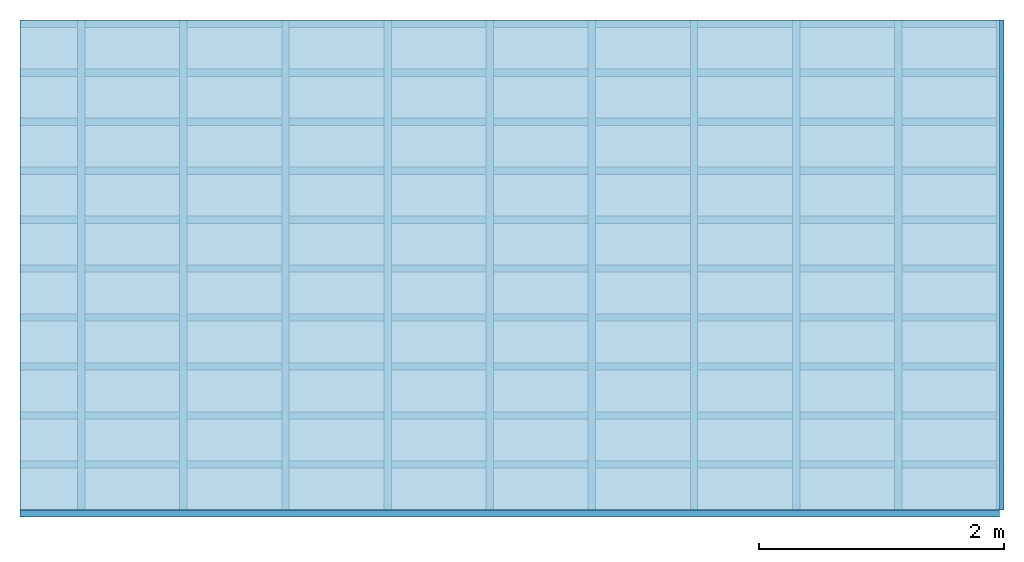
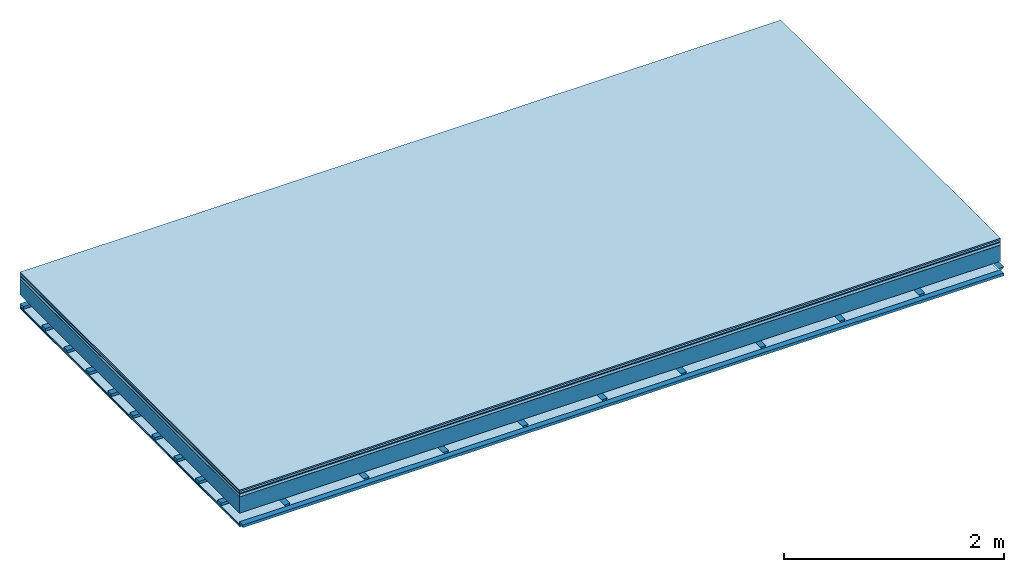
# One storey: 8 plates, 3 members, 1 element without a shape of its own.
"""IFC4 building model written with IfcOpenShell, lengths in metres."""

from ifc_helpers import new_model, si_unit, derived_unit, direction, frame, frame_2d, origin, origin_with_axes, place, context, project, spatial, polyline, rectangle, outline, extrude, material, layer, layer_set, type_object, element, aggregate, save


model = new_model("IFC4")

# Units and contexts
plan_context = context("Plan", 3, precision=1e-05, world=origin(), true_north=direction((0.0, 1.0)))
model_context = context("Model", 3, precision=1e-05, world=origin(), true_north=direction((0.0, 1.0)))
ifc_project = project(units=[si_unit("LENGTHUNIT", "METRE"), derived_unit("SOUNDPRESSUREUNIT", [(si_unit("PRESSUREUNIT", "PASCAL", prefix="MICRO"), 0)]), si_unit("ENERGYUNIT", "JOULE", prefix="MEGA"), si_unit("MASSUNIT", "GRAM", prefix="KILO"), derived_unit("THERMALTRANSMITTANCEUNIT", [(si_unit("POWERUNIT", "WATT"), 1), (si_unit("AREAUNIT", "SQUARE_METRE"), -1), (si_unit("THERMODYNAMICTEMPERATUREUNIT", "KELVIN"), -1)]), derived_unit("AREADENSITYUNIT", [(si_unit("MASSUNIT", "GRAM", prefix="KILO"), 1), (si_unit("AREAUNIT", "SQUARE_METRE"), -1)]), derived_unit("USERDEFINED", [(si_unit("ENERGYUNIT", "JOULE", prefix="MEGA"), 1), (si_unit("AREAUNIT", "SQUARE_METRE"), -1)])], contexts=[plan_context, model_context])

# Site, building, storey
site = spatial("IfcSite", under=ifc_project)
building_placement = place(None, origin())
building = spatial("IfcBuilding", under=site, at=building_placement)
storey_placement = place(building_placement, origin())
storey = spatial("IfcBuildingStorey", under=building, at=storey_placement)

# Slab, members, plates
ifc_material_1 = material(Category="11.013")
ifc_layer_1 = layer(ifc_material_1, 0.015, Name="Flooring")
ifc_material_2 = material(Category="03.007")
ifc_layer_2 = layer(ifc_material_2, 0.02, Name="On-material")
ifc_material_3 = material(Name="Wood fiber generic product", Category="10.009")
ifc_layer_3 = layer(ifc_material_3, 0.01, Name="Impact sound insulation")
ifc_material_4 = material(Name="with broken")
ifc_layer_4 = layer(ifc_material_4, 0.03, Name="on Supporting structure")
ifc_material_5 = material(Name="protection", Category="09.007")
ifc_layer_5 = layer(ifc_material_5, 0.0005, Name="Sub-floor")
ifc_material_6 = material(Name="no composite action")
ifc_layer_6 = layer(ifc_material_6, 0.0, Name="Bond")
ifc_layer_7 = layer(None, 0.18, Name="Supporting structure")
ifc_layer_8 = layer(ifc_material_6, 0.0, Name="Bond")
ifc_layer_9 = layer(None, 0.095, Name="Coupling")
ifc_layer_10 = layer(None, 0.03, Name="Battens / profiles")
ifc_material_7 = material(Name="Plasterboard type A", Category="03.008")
ifc_layer_11 = layer(ifc_material_7, 0.0125, Name="Ceiling covering 1st layer")
ifc_layer_12 = layer(ifc_material_7, 0.0125, Name="Ceiling covering layer 2")
ifc_material_8 = material(Category="04.001")
ifc_layer_13 = layer(ifc_material_8, 0.003, Name="Surface / treatment")
ifc_layer_set = layer_set([ifc_layer_1, ifc_layer_2, ifc_layer_3, ifc_layer_4, ifc_layer_5, ifc_layer_6, ifc_layer_7, ifc_layer_8, ifc_layer_9, ifc_layer_10, ifc_layer_11, ifc_layer_12, ifc_layer_13])
slab_type = type_object("IfcSlabType", Name="A2117", PredefinedType="NOTDEFINED", material=ifc_layer_set)
slab_placement = place(None, frame((0.0, 0.0, 0.0), z_axis=(0.0, 0.0, -1.0), x_axis=(1.0, 0.0, 0.0)))
slab = element("IfcSlab", 1, at=slab_placement, inside=storey, type_object=slab_type, material=ifc_layer_set, Name="Slab #1")
ifc_material_9 = material(Name="Solid timber panel")
member_1_placement = place(slab_placement, origin())
member_1 = element("IfcMember", 2, at=member_1_placement, material=ifc_material_9, Name="Supporting structure", context=plan_context, shape_type="SweptSolid", body=[
    extrude(rectangle(XDim=1.0, YDim=0.18, at=frame_2d((0.5, 0.09), x_axis=(1.0, 0.0))), frame((0.0, 4.0, 0.0755), z_axis=(0.0, -1.0, 0.0), x_axis=(1.0, 0.0, 0.0)), (0.0, 0.0, 1.0), 4.0),
    extrude(rectangle(XDim=1.0, YDim=0.18, at=frame_2d((0.5, 0.09), x_axis=(1.0, 0.0))), frame((1.0, 4.0, 0.0755), z_axis=(0.0, -1.0, 0.0), x_axis=(1.0, 0.0, 0.0)), (0.0, 0.0, 1.0), 4.0),
    extrude(rectangle(XDim=1.0, YDim=0.18, at=frame_2d((0.5, 0.09), x_axis=(1.0, 0.0))), frame((2.0, 4.0, 0.0755), z_axis=(0.0, -1.0, 0.0), x_axis=(1.0, 0.0, 0.0)), (0.0, 0.0, 1.0), 4.0),
    extrude(rectangle(XDim=1.0, YDim=0.18, at=frame_2d((0.5, 0.09), x_axis=(1.0, 0.0))), frame((3.0, 4.0, 0.0755), z_axis=(0.0, -1.0, 0.0), x_axis=(1.0, 0.0, 0.0)), (0.0, 0.0, 1.0), 4.0),
    extrude(rectangle(XDim=1.0, YDim=0.18, at=frame_2d((0.5, 0.09), x_axis=(1.0, 0.0))), frame((4.0, 4.0, 0.0755), z_axis=(0.0, -1.0, 0.0), x_axis=(1.0, 0.0, 0.0)), (0.0, 0.0, 1.0), 4.0),
    extrude(rectangle(XDim=1.0, YDim=0.18, at=frame_2d((0.5, 0.09), x_axis=(1.0, 0.0))), frame((5.0, 4.0, 0.0755), z_axis=(0.0, -1.0, 0.0), x_axis=(1.0, 0.0, 0.0)), (0.0, 0.0, 1.0), 4.0),
    extrude(rectangle(XDim=1.0, YDim=0.18, at=frame_2d((0.5, 0.09), x_axis=(1.0, 0.0))), frame((6.0, 4.0, 0.0755), z_axis=(0.0, -1.0, 0.0), x_axis=(1.0, 0.0, 0.0)), (0.0, 0.0, 1.0), 4.0),
    extrude(rectangle(XDim=1.0, YDim=0.18, at=frame_2d((0.5, 0.09), x_axis=(1.0, 0.0))), frame((7.0, 4.0, 0.0755), z_axis=(0.0, -1.0, 0.0), x_axis=(1.0, 0.0, 0.0)), (0.0, 0.0, 1.0), 4.0),
])
ifc_material_10 = material()
member_2_placement = place(slab_placement, origin())
member_2 = element("IfcMember", 3, at=member_2_placement, material=ifc_material_10, Name="Coupling", context=plan_context, shape_type="SweptSolid", body=[
    extrude(outline(polyline([(0.0, 0.0), (0.06, 0.0), (0.04, 0.02), (0.02, 0.02), (0.0, 0.0)])), frame((0.47, 4.0, 0.3305), z_axis=(0.0, -1.0, 0.0), x_axis=(1.0, 0.0, 0.0)), (0.0, 0.0, 1.0), 4.0),
    extrude(outline(polyline([(0.0, 0.0), (0.06, 0.0), (0.04, 0.02), (0.02, 0.02), (0.0, 0.0)])), frame((1.304, 4.0, 0.3305), z_axis=(0.0, -1.0, 0.0), x_axis=(1.0, 0.0, 0.0)), (0.0, 0.0, 1.0), 4.0),
    extrude(outline(polyline([(0.0, 0.0), (0.06, 0.0), (0.04, 0.02), (0.02, 0.02), (0.0, 0.0)])), frame((2.138, 4.0, 0.3305), z_axis=(0.0, -1.0, 0.0), x_axis=(1.0, 0.0, 0.0)), (0.0, 0.0, 1.0), 4.0),
    extrude(outline(polyline([(0.0, 0.0), (0.06, 0.0), (0.04, 0.02), (0.02, 0.02), (0.0, 0.0)])), frame((2.972, 4.0, 0.3305), z_axis=(0.0, -1.0, 0.0), x_axis=(1.0, 0.0, 0.0)), (0.0, 0.0, 1.0), 4.0),
    extrude(outline(polyline([(0.0, 0.0), (0.06, 0.0), (0.04, 0.02), (0.02, 0.02), (0.0, 0.0)])), frame((3.806, 4.0, 0.3305), z_axis=(0.0, -1.0, 0.0), x_axis=(1.0, 0.0, 0.0)), (0.0, 0.0, 1.0), 4.0),
    extrude(outline(polyline([(0.0, 0.0), (0.06, 0.0), (0.04, 0.02), (0.02, 0.02), (0.0, 0.0)])), frame((4.64, 4.0, 0.3305), z_axis=(0.0, -1.0, 0.0), x_axis=(1.0, 0.0, 0.0)), (0.0, 0.0, 1.0), 4.0),
    extrude(outline(polyline([(0.0, 0.0), (0.06, 0.0), (0.04, 0.02), (0.02, 0.02), (0.0, 0.0)])), frame((5.474, 4.0, 0.3305), z_axis=(0.0, -1.0, 0.0), x_axis=(1.0, 0.0, 0.0)), (0.0, 0.0, 1.0), 4.0),
    extrude(outline(polyline([(0.0, 0.0), (0.06, 0.0), (0.04, 0.02), (0.02, 0.02), (0.0, 0.0)])), frame((6.308, 4.0, 0.3305), z_axis=(0.0, -1.0, 0.0), x_axis=(1.0, 0.0, 0.0)), (0.0, 0.0, 1.0), 4.0),
    extrude(outline(polyline([(0.0, 0.0), (0.06, 0.0), (0.04, 0.02), (0.02, 0.02), (0.0, 0.0)])), frame((7.142, 4.0, 0.3305), z_axis=(0.0, -1.0, 0.0), x_axis=(1.0, 0.0, 0.0)), (0.0, 0.0, 1.0), 4.0),
    extrude(outline(polyline([(0.0, 0.0), (0.06, 0.0), (0.04, 0.02), (0.02, 0.02), (0.0, 0.0)])), frame((7.976, 4.0, 0.3305), z_axis=(0.0, -1.0, 0.0), x_axis=(1.0, 0.0, 0.0)), (0.0, 0.0, 1.0), 4.0),
])
member_3_placement = place(slab_placement, origin())
member_3 = element("IfcMember", 4, at=member_3_placement, material=ifc_material_10, Name="Battens / profiles", context=plan_context, shape_type="SweptSolid", body=[
    extrude(rectangle(XDim=0.06, YDim=0.03, at=frame_2d((0.03, 0.015), x_axis=(1.0, 0.0))), frame((0.0, 0.0, 0.3505), z_axis=(1.0, 0.0, 0.0), x_axis=(0.0, 1.0, 0.0)), (0.0, 0.0, 1.0), 8.0),
    extrude(rectangle(XDim=0.06, YDim=0.03, at=frame_2d((0.03, 0.015), x_axis=(1.0, 0.0))), frame((0.0, 0.4, 0.3505), z_axis=(1.0, 0.0, 0.0), x_axis=(0.0, 1.0, 0.0)), (0.0, 0.0, 1.0), 8.0),
    extrude(rectangle(XDim=0.06, YDim=0.03, at=frame_2d((0.03, 0.015), x_axis=(1.0, 0.0))), frame((0.0, 0.8, 0.3505), z_axis=(1.0, 0.0, 0.0), x_axis=(0.0, 1.0, 0.0)), (0.0, 0.0, 1.0), 8.0),
    extrude(rectangle(XDim=0.06, YDim=0.03, at=frame_2d((0.03, 0.015), x_axis=(1.0, 0.0))), frame((0.0, 1.2, 0.3505), z_axis=(1.0, 0.0, 0.0), x_axis=(0.0, 1.0, 0.0)), (0.0, 0.0, 1.0), 8.0),
    extrude(rectangle(XDim=0.06, YDim=0.03, at=frame_2d((0.03, 0.015), x_axis=(1.0, 0.0))), frame((0.0, 1.6, 0.3505), z_axis=(1.0, 0.0, 0.0), x_axis=(0.0, 1.0, 0.0)), (0.0, 0.0, 1.0), 8.0),
    extrude(rectangle(XDim=0.06, YDim=0.03, at=frame_2d((0.03, 0.015), x_axis=(1.0, 0.0))), frame((0.0, 2.0, 0.3505), z_axis=(1.0, 0.0, 0.0), x_axis=(0.0, 1.0, 0.0)), (0.0, 0.0, 1.0), 8.0),
    extrude(rectangle(XDim=0.06, YDim=0.03, at=frame_2d((0.03, 0.015), x_axis=(1.0, 0.0))), frame((0.0, 2.4, 0.3505), z_axis=(1.0, 0.0, 0.0), x_axis=(0.0, 1.0, 0.0)), (0.0, 0.0, 1.0), 8.0),
    extrude(rectangle(XDim=0.06, YDim=0.03, at=frame_2d((0.03, 0.015), x_axis=(1.0, 0.0))), frame((0.0, 2.8, 0.3505), z_axis=(1.0, 0.0, 0.0), x_axis=(0.0, 1.0, 0.0)), (0.0, 0.0, 1.0), 8.0),
    extrude(rectangle(XDim=0.06, YDim=0.03, at=frame_2d((0.03, 0.015), x_axis=(1.0, 0.0))), frame((0.0, 3.2, 0.3505), z_axis=(1.0, 0.0, 0.0), x_axis=(0.0, 1.0, 0.0)), (0.0, 0.0, 1.0), 8.0),
    extrude(rectangle(XDim=0.06, YDim=0.03, at=frame_2d((0.03, 0.015), x_axis=(1.0, 0.0))), frame((0.0, 3.6, 0.3505), z_axis=(1.0, 0.0, 0.0), x_axis=(0.0, 1.0, 0.0)), (0.0, 0.0, 1.0), 8.0),
    extrude(rectangle(XDim=0.06, YDim=0.03, at=frame_2d((0.03, 0.015), x_axis=(1.0, 0.0))), frame((0.0, 4.0, 0.3505), z_axis=(1.0, 0.0, 0.0), x_axis=(0.0, 1.0, 0.0)), (0.0, 0.0, 1.0), 8.0),
])
plate_1_placement = place(slab_placement, origin())
plate_1 = element("IfcPlate", 5, at=plate_1_placement, material=ifc_material_1, Name="Flooring", context=plan_context, shape_type="SweptSolid", body=[
    extrude(rectangle(XDim=8.0, YDim=4.0, at=frame_2d((4.0, 2.0), x_axis=(1.0, 0.0))), origin_with_axes(), (0.0, 0.0, 1.0), 0.015),
])
plate_2_placement = place(slab_placement, origin())
plate_2 = element("IfcPlate", 6, at=plate_2_placement, material=ifc_material_2, Name="On-material", context=plan_context, shape_type="SweptSolid", body=[
    extrude(rectangle(XDim=8.0, YDim=4.0, at=frame_2d((4.0, 2.0), x_axis=(1.0, 0.0))), frame((0.0, 0.0, 0.015), z_axis=(0.0, 0.0, 1.0), x_axis=(1.0, 0.0, 0.0)), (0.0, 0.0, 1.0), 0.02),
])
plate_3_placement = place(slab_placement, origin())
plate_3 = element("IfcPlate", 7, at=plate_3_placement, material=ifc_material_3, Name="Impact sound insulation", context=plan_context, shape_type="SweptSolid", body=[
    extrude(rectangle(XDim=8.0, YDim=4.0, at=frame_2d((4.0, 2.0), x_axis=(1.0, 0.0))), frame((0.0, 0.0, 0.035), z_axis=(0.0, 0.0, 1.0), x_axis=(1.0, 0.0, 0.0)), (0.0, 0.0, 1.0), 0.01),
])
plate_4_placement = place(slab_placement, origin())
plate_4 = element("IfcPlate", 8, at=plate_4_placement, material=ifc_material_4, Name="on Supporting structure", context=plan_context, shape_type="SweptSolid", body=[
    extrude(rectangle(XDim=8.0, YDim=4.0, at=frame_2d((4.0, 2.0), x_axis=(1.0, 0.0))), frame((0.0, 0.0, 0.045), z_axis=(0.0, 0.0, 1.0), x_axis=(1.0, 0.0, 0.0)), (0.0, 0.0, 1.0), 0.03),
])
plate_5_placement = place(slab_placement, origin())
plate_5 = element("IfcPlate", 9, at=plate_5_placement, material=ifc_material_5, Name="Sub-floor", context=plan_context, shape_type="SweptSolid", body=[
    extrude(rectangle(XDim=8.0, YDim=4.0, at=frame_2d((4.0, 2.0), x_axis=(1.0, 0.0))), frame((0.0, 0.0, 0.075), z_axis=(0.0, 0.0, 1.0), x_axis=(1.0, 0.0, 0.0)), (0.0, 0.0, 1.0), 0.0005),
])
plate_6_placement = place(slab_placement, origin())
plate_6 = element("IfcPlate", 10, at=plate_6_placement, material=ifc_material_7, Name="Ceiling covering 1st layer", context=plan_context, shape_type="SweptSolid", body=[
    extrude(rectangle(XDim=8.0, YDim=4.0, at=frame_2d((4.0, 2.0), x_axis=(1.0, 0.0))), frame((0.0, 0.0, 0.3805), z_axis=(0.0, 0.0, 1.0), x_axis=(1.0, 0.0, 0.0)), (0.0, 0.0, 1.0), 0.0125),
])
plate_7_placement = place(slab_placement, origin())
plate_7 = element("IfcPlate", 11, at=plate_7_placement, material=ifc_material_7, Name="Ceiling covering layer 2", context=plan_context, shape_type="SweptSolid", body=[
    extrude(rectangle(XDim=8.0, YDim=4.0, at=frame_2d((4.0, 2.0), x_axis=(1.0, 0.0))), frame((0.0, 0.0, 0.393), z_axis=(0.0, 0.0, 1.0), x_axis=(1.0, 0.0, 0.0)), (0.0, 0.0, 1.0), 0.0125),
])
plate_8_placement = place(slab_placement, origin())
plate_8 = element("IfcPlate", 12, at=plate_8_placement, material=ifc_material_8, Name="Surface / treatment", context=plan_context, shape_type="SweptSolid", body=[
    extrude(rectangle(XDim=8.0, YDim=4.0, at=frame_2d((4.0, 2.0), x_axis=(1.0, 0.0))), frame((0.0, 0.0, 0.4055), z_axis=(0.0, 0.0, 1.0), x_axis=(1.0, 0.0, 0.0)), (0.0, 0.0, 1.0), 0.003),
])
aggregate(slab, [plate_1, plate_2, plate_3, plate_4, plate_5, member_1, member_2, member_3, plate_6, plate_7, plate_8])

save(model, "model.ifc")
